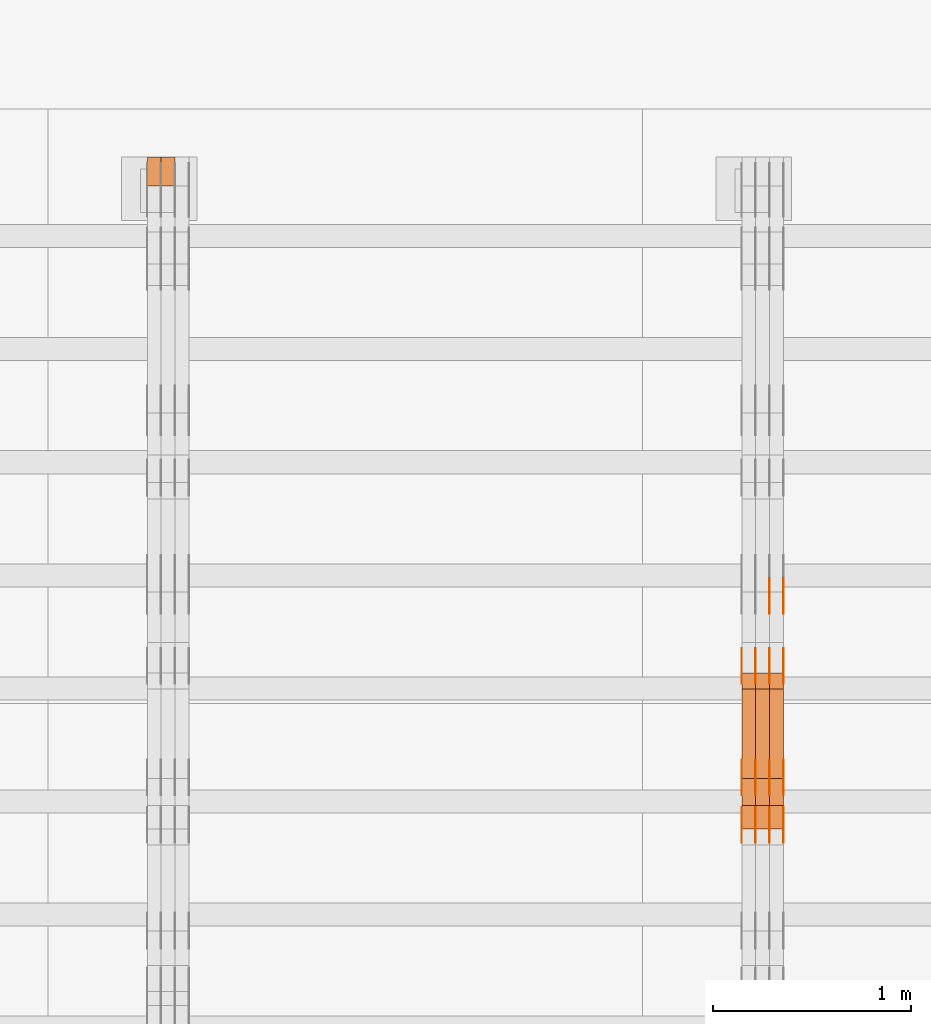
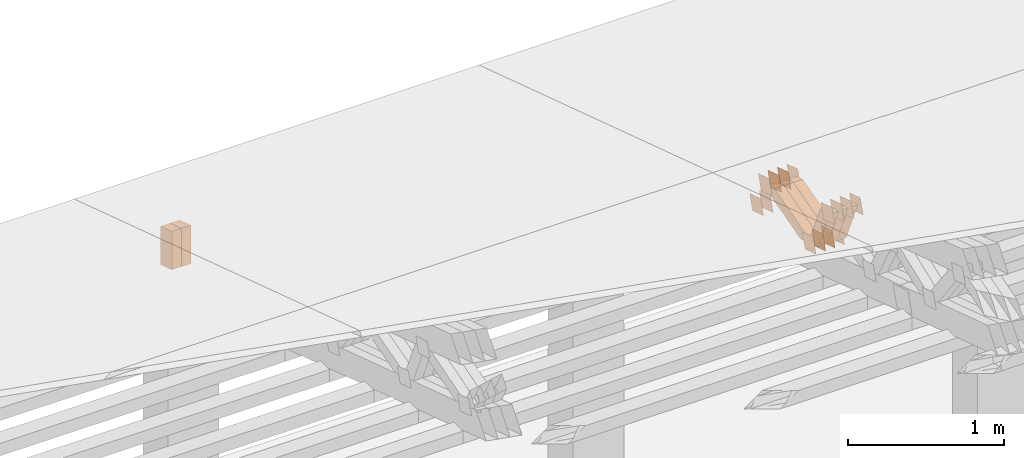
# One storey, part 220 of 385: 28 proxies.
"""IFC2X3 building model written with IfcOpenShell, lengths in millimetres."""

from ifc_helpers import new_model, entity, si_unit, converted_unit, derived_unit, direction, frame, origin, place, context, subcontext, project, spatial, polyline, outline, extrude, source, transform, mapped, material, type_object, type_shapes, element, save


model = new_model("IFC2X3")

# Units and contexts
model_context = context("Model", 3, precision=0.01, world=origin(), true_north=direction((6.12303176911189e-17, 1.0)))
body_context = subcontext(model_context, "Body", "Model", "MODEL_VIEW")
ifc_project = project(units=[si_unit("LENGTHUNIT", "METRE", prefix="MILLI"), si_unit("AREAUNIT", "SQUARE_METRE"), si_unit("VOLUMEUNIT", "CUBIC_METRE"), converted_unit("PLANEANGLEUNIT", "DEGREE", entity("IfcRatioMeasure", 0.0174532925199433), si_unit("PLANEANGLEUNIT", "RADIAN"), dimensions=[0, 0, 0, 0, 0, 0, 0]), si_unit("MASSUNIT", "GRAM", prefix="KILO"), derived_unit("MASSDENSITYUNIT", [(si_unit("MASSUNIT", "GRAM", prefix="KILO"), 1), (si_unit("LENGTHUNIT", "METRE"), -3)]), si_unit("TIMEUNIT", "SECOND"), si_unit("FREQUENCYUNIT", "HERTZ"), si_unit("THERMODYNAMICTEMPERATUREUNIT", "DEGREE_CELSIUS"), derived_unit("THERMALTRANSMITTANCEUNIT", [(si_unit("MASSUNIT", "GRAM", prefix="KILO"), 1), (si_unit("THERMODYNAMICTEMPERATUREUNIT", "KELVIN"), -1), (si_unit("TIMEUNIT", "SECOND"), -3)]), derived_unit("VOLUMETRICFLOWRATEUNIT", [(si_unit("LENGTHUNIT", "METRE"), 3), (si_unit("TIMEUNIT", "SECOND"), -1)]), si_unit("ELECTRICCURRENTUNIT", "AMPERE"), si_unit("ELECTRICVOLTAGEUNIT", "VOLT"), si_unit("POWERUNIT", "WATT"), si_unit("FORCEUNIT", "NEWTON", prefix="KILO"), si_unit("ILLUMINANCEUNIT", "LUX"), si_unit("LUMINOUSFLUXUNIT", "LUMEN"), si_unit("LUMINOUSINTENSITYUNIT", "CANDELA"), derived_unit("USERDEFINED", [(si_unit("MASSUNIT", "GRAM", prefix="KILO"), -1), (si_unit("LENGTHUNIT", "METRE"), -2), (si_unit("TIMEUNIT", "SECOND"), 3), (si_unit("LUMINOUSFLUXUNIT", "LUMEN"), 1)]), derived_unit("LINEARVELOCITYUNIT", [(si_unit("LENGTHUNIT", "METRE"), 1), (si_unit("TIMEUNIT", "SECOND"), -1)]), si_unit("PRESSUREUNIT", "PASCAL"), derived_unit("USERDEFINED", [(si_unit("LENGTHUNIT", "METRE"), -2), (si_unit("MASSUNIT", "GRAM", prefix="KILO"), 1), (si_unit("TIMEUNIT", "SECOND"), -2)])], contexts=[model_context])

# Site, building, storey
site_placement = place(None, origin())
site = spatial("IfcSite", under=ifc_project, at=site_placement, CompositionType="ELEMENT")
building_placement = place(site_placement, origin())
building = spatial("IfcBuilding", under=site, at=building_placement, CompositionType="ELEMENT")
storey_placement = place(building_placement, origin())
storey = spatial("IfcBuildingStorey", under=building, at=storey_placement, Name="Default", CompositionType="ELEMENT", Elevation=0.0)

# Proxies
ifc_material_1 = material(Name="IfcSurfaceStyle #265350")
building_element_proxy_type_1 = type_object("IfcBuildingElementProxyType", PredefinedType="NOTDEFINED", material=ifc_material_1)
shared_shape_1 = source(origin(), body_context, "Body", "SweptSolid", [
    extrude(outline(polyline([(-74.9998888504569, -59.9999264677525), (74.999884859074, -59.9999264677525), (74.9998699895559, 59.9999264677525), (-74.999865998173, 59.9999264677525), (-74.9998888504569, -59.9999264677525)])), frame((74.9999170714918, 60.0000016373507, 0.0), z_axis=(0.0, 0.0, 1.0), x_axis=(-1.0, 0.0, 0.0)), (0.0, 0.0, 1.0), 1.3),
])
type_shapes(building_element_proxy_type_1, [shared_shape_1])
proxy_1_placement = place(building_placement, frame((21386.3, 23182.5962361838, 1409.76695322432), z_axis=(-1.0, 0.0, 0.0), x_axis=(0.0, -0.951056516295154, 0.309016994374948)))
element("IfcBuildingElementProxy", 1, at=proxy_1_placement, inside=storey, type_object=building_element_proxy_type_1, material=ifc_material_1, context=body_context, shape_type="MappedRepresentation", body=[
    mapped(shared_shape_1, transform((0.0, 0.0, 0.0), scale=1.0)),
])
ifc_material_2 = material(Name="IfcSurfaceStyle #265293")
building_element_proxy_type_2 = type_object("IfcBuildingElementProxyType", PredefinedType="NOTDEFINED", material=ifc_material_2)
shared_shape_2 = source(origin(), body_context, "Body", "SweptSolid", [
    extrude(outline(polyline([(-74.9998888504569, -59.9999264677525), (74.999884859074, -59.9999264677525), (74.9998699895559, 59.9999264677525), (-74.999865998173, 59.9999264677525), (-74.9998888504569, -59.9999264677525)])), frame((74.9999170714918, 60.0000016373507, 0.0), z_axis=(0.0, 0.0, 1.0), x_axis=(-1.0, 0.0, 0.0)), (0.0, 0.0, 1.0), 1.3),
])
type_shapes(building_element_proxy_type_2, [shared_shape_2])
proxy_2_placement = place(building_placement, frame((21315.0, 23182.5962361838, 1409.76695322432), z_axis=(-1.0, 0.0, 0.0), x_axis=(0.0, -0.951056516295154, 0.309016994374948)))
element("IfcBuildingElementProxy", 2, at=proxy_2_placement, inside=storey, type_object=building_element_proxy_type_2, material=ifc_material_2, context=body_context, shape_type="MappedRepresentation", body=[
    mapped(shared_shape_2, transform((0.0, 0.0, 0.0), scale=1.0)),
])
ifc_material_3 = material(Name="IfcSurfaceStyle #265236")
building_element_proxy_type_3 = type_object("IfcBuildingElementProxyType", PredefinedType="NOTDEFINED", material=ifc_material_3)
shared_shape_3 = source(origin(), body_context, "Body", "SweptSolid", [
    extrude(outline(polyline([(-74.9998888504569, -59.9999264677525), (74.999884859074, -59.9999264677525), (74.9998699895559, 59.9999264677525), (-74.999865998173, 59.9999264677525), (-74.9998888504569, -59.9999264677525)])), frame((74.9999170714918, 60.0000016373507, 0.0), z_axis=(0.0, 0.0, 1.0), x_axis=(-1.0, 0.0, 0.0)), (0.0, 0.0, 1.0), 1.3),
])
type_shapes(building_element_proxy_type_3, [shared_shape_3])
proxy_3_placement = place(building_placement, frame((21316.3, 23182.5962361838, 1409.76695322432), z_axis=(-1.0, 0.0, 0.0), x_axis=(0.0, -0.951056516295154, 0.309016994374948)))
element("IfcBuildingElementProxy", 3, at=proxy_3_placement, inside=storey, type_object=building_element_proxy_type_3, material=ifc_material_3, context=body_context, shape_type="MappedRepresentation", body=[
    mapped(shared_shape_3, transform((0.0, 0.0, 0.0), scale=1.0)),
])
ifc_material_4 = material(Name="IfcSurfaceStyle #265179")
building_element_proxy_type_4 = type_object("IfcBuildingElementProxyType", PredefinedType="NOTDEFINED", material=ifc_material_4)
shared_shape_4 = source(origin(), body_context, "Body", "SweptSolid", [
    extrude(outline(polyline([(-74.9998888504569, -59.9999264677525), (74.999884859074, -59.9999264677525), (74.9998699895559, 59.9999264677525), (-74.999865998173, 59.9999264677525), (-74.9998888504569, -59.9999264677525)])), frame((74.9999170714918, 60.0000016373507, 0.0), z_axis=(0.0, 0.0, 1.0), x_axis=(-1.0, 0.0, 0.0)), (0.0, 0.0, 1.0), 1.29999999999999),
])
type_shapes(building_element_proxy_type_4, [shared_shape_4])
proxy_4_placement = place(building_placement, frame((21245.0, 23182.5962361838, 1409.76695322432), z_axis=(-1.0, 0.0, 0.0), x_axis=(0.0, -0.951056516295154, 0.309016994374948)))
element("IfcBuildingElementProxy", 4, at=proxy_4_placement, inside=storey, type_object=building_element_proxy_type_4, material=ifc_material_4, context=body_context, shape_type="MappedRepresentation", body=[
    mapped(shared_shape_4, transform((0.0, 0.0, 0.0), scale=1.0)),
])
ifc_material_5 = material(Name="IfcSurfaceStyle #265122")
building_element_proxy_type_5 = type_object("IfcBuildingElementProxyType", PredefinedType="NOTDEFINED", material=ifc_material_5)
shared_shape_5 = source(origin(), body_context, "Body", "SweptSolid", [
    extrude(outline(polyline([(-74.9998888504569, -59.9999264677525), (74.999884859074, -59.9999264677525), (74.9998699895559, 59.9999264677525), (-74.999865998173, 59.9999264677525), (-74.9998888504569, -59.9999264677525)])), frame((74.9999170714918, 60.0000016373507, 0.0), z_axis=(0.0, 0.0, 1.0), x_axis=(-1.0, 0.0, 0.0)), (0.0, 0.0, 1.0), 1.29999999999999),
])
type_shapes(building_element_proxy_type_5, [shared_shape_5])
proxy_5_placement = place(building_placement, frame((21246.3, 23182.5962361838, 1409.76695322432), z_axis=(-1.0, 0.0, 0.0), x_axis=(0.0, -0.951056516295154, 0.309016994374948)))
element("IfcBuildingElementProxy", 5, at=proxy_5_placement, inside=storey, type_object=building_element_proxy_type_5, material=ifc_material_5, context=body_context, shape_type="MappedRepresentation", body=[
    mapped(shared_shape_5, transform((0.0, 0.0, 0.0), scale=1.0)),
])
ifc_material_6 = material(Name="IfcSurfaceStyle #265065")
building_element_proxy_type_6 = type_object("IfcBuildingElementProxyType", PredefinedType="NOTDEFINED", material=ifc_material_6)
shared_shape_6 = source(origin(), body_context, "Body", "SweptSolid", [
    extrude(outline(polyline([(-74.9998888504569, -59.9999264677525), (74.999884859074, -59.9999264677525), (74.9998699895559, 59.9999264677525), (-74.999865998173, 59.9999264677525), (-74.9998888504569, -59.9999264677525)])), frame((74.9999170714918, 60.0000016373507, 0.0), z_axis=(0.0, 0.0, 1.0), x_axis=(-1.0, 0.0, 0.0)), (0.0, 0.0, 1.0), 1.29999999999999),
])
type_shapes(building_element_proxy_type_6, [shared_shape_6])
proxy_6_placement = place(building_placement, frame((21175.0, 23182.5962361838, 1409.76695322432), z_axis=(-1.0, 0.0, 0.0), x_axis=(0.0, -0.951056516295154, 0.309016994374948)))
element("IfcBuildingElementProxy", 6, at=proxy_6_placement, inside=storey, type_object=building_element_proxy_type_6, material=ifc_material_6, context=body_context, shape_type="MappedRepresentation", body=[
    mapped(shared_shape_6, transform((0.0, 0.0, 0.0), scale=1.0)),
])
ifc_material_7 = material(Name="IfcSurfaceStyle #265008")
building_element_proxy_type_7 = type_object("IfcBuildingElementProxyType", PredefinedType="NOTDEFINED", material=ifc_material_7)
shared_shape_7 = source(origin(), body_context, "Body", "SweptSolid", [
    extrude(outline(polyline([(-75.000111611545, -60.0000599592451), (75.0000887592491, -60.0000599592451), (75.000111611545, 60.0000599592451), (-75.0000887592492, 60.0000599592451), (-75.000111611545, -60.0000599592451)])), frame((75.000111611545, 60.0000599592451, 0.0), z_axis=(0.0, 0.0, 1.0), x_axis=(-1.0, 0.0, 0.0)), (0.0, 0.0, 1.0), 1.3),
])
type_shapes(building_element_proxy_type_7, [shared_shape_7])
proxy_7_placement = place(building_placement, frame((21386.3, 23422.738257852, 1031.33757447264), z_axis=(-1.0, 0.0, 0.0), x_axis=(0.0, -0.951056516295124, 0.309016994375039)))
element("IfcBuildingElementProxy", 7, at=proxy_7_placement, inside=storey, type_object=building_element_proxy_type_7, material=ifc_material_7, context=body_context, shape_type="MappedRepresentation", body=[
    mapped(shared_shape_7, transform((0.0, 0.0, 0.0), scale=1.0)),
])
ifc_material_8 = material(Name="IfcSurfaceStyle #264951")
building_element_proxy_type_8 = type_object("IfcBuildingElementProxyType", PredefinedType="NOTDEFINED", material=ifc_material_8)
shared_shape_8 = source(origin(), body_context, "Body", "SweptSolid", [
    extrude(outline(polyline([(-75.000111611545, -60.0000599592451), (75.0000887592491, -60.0000599592451), (75.000111611545, 60.0000599592451), (-75.0000887592492, 60.0000599592451), (-75.000111611545, -60.0000599592451)])), frame((75.000111611545, 60.0000599592451, 0.0), z_axis=(0.0, 0.0, 1.0), x_axis=(-1.0, 0.0, 0.0)), (0.0, 0.0, 1.0), 1.3),
])
type_shapes(building_element_proxy_type_8, [shared_shape_8])
proxy_8_placement = place(building_placement, frame((21315.0, 23422.738257852, 1031.33757447264), z_axis=(-1.0, 0.0, 0.0), x_axis=(0.0, -0.951056516295124, 0.309016994375039)))
element("IfcBuildingElementProxy", 8, at=proxy_8_placement, inside=storey, type_object=building_element_proxy_type_8, material=ifc_material_8, context=body_context, shape_type="MappedRepresentation", body=[
    mapped(shared_shape_8, transform((0.0, 0.0, 0.0), scale=1.0)),
])
ifc_material_9 = material(Name="IfcSurfaceStyle #264894")
building_element_proxy_type_9 = type_object("IfcBuildingElementProxyType", PredefinedType="NOTDEFINED", material=ifc_material_9)
shared_shape_9 = source(origin(), body_context, "Body", "SweptSolid", [
    extrude(outline(polyline([(-75.000111611545, -60.0000599592451), (75.0000887592491, -60.0000599592451), (75.000111611545, 60.0000599592451), (-75.0000887592492, 60.0000599592451), (-75.000111611545, -60.0000599592451)])), frame((75.000111611545, 60.0000599592451, 0.0), z_axis=(0.0, 0.0, 1.0), x_axis=(-1.0, 0.0, 0.0)), (0.0, 0.0, 1.0), 1.3),
])
type_shapes(building_element_proxy_type_9, [shared_shape_9])
proxy_9_placement = place(building_placement, frame((21316.3, 23422.738257852, 1031.33757447264), z_axis=(-1.0, 0.0, 0.0), x_axis=(0.0, -0.951056516295124, 0.309016994375039)))
element("IfcBuildingElementProxy", 9, at=proxy_9_placement, inside=storey, type_object=building_element_proxy_type_9, material=ifc_material_9, context=body_context, shape_type="MappedRepresentation", body=[
    mapped(shared_shape_9, transform((0.0, 0.0, 0.0), scale=1.0)),
])
ifc_material_10 = material(Name="IfcSurfaceStyle #264837")
building_element_proxy_type_10 = type_object("IfcBuildingElementProxyType", PredefinedType="NOTDEFINED", material=ifc_material_10)
shared_shape_10 = source(origin(), body_context, "Body", "SweptSolid", [
    extrude(outline(polyline([(-75.000111611545, -60.0000599592451), (75.0000887592491, -60.0000599592451), (75.000111611545, 60.0000599592451), (-75.0000887592492, 60.0000599592451), (-75.000111611545, -60.0000599592451)])), frame((75.000111611545, 60.0000599592451, 0.0), z_axis=(0.0, 0.0, 1.0), x_axis=(-1.0, 0.0, 0.0)), (0.0, 0.0, 1.0), 1.29999999999999),
])
type_shapes(building_element_proxy_type_10, [shared_shape_10])
proxy_10_placement = place(building_placement, frame((21245.0, 23422.738257852, 1031.33757447264), z_axis=(-1.0, 0.0, 0.0), x_axis=(0.0, -0.951056516295124, 0.309016994375039)))
element("IfcBuildingElementProxy", 10, at=proxy_10_placement, inside=storey, type_object=building_element_proxy_type_10, material=ifc_material_10, context=body_context, shape_type="MappedRepresentation", body=[
    mapped(shared_shape_10, transform((0.0, 0.0, 0.0), scale=1.0)),
])
ifc_material_11 = material(Name="IfcSurfaceStyle #264780")
building_element_proxy_type_11 = type_object("IfcBuildingElementProxyType", PredefinedType="NOTDEFINED", material=ifc_material_11)
shared_shape_11 = source(origin(), body_context, "Body", "SweptSolid", [
    extrude(outline(polyline([(-75.000111611545, -60.0000599592451), (75.0000887592491, -60.0000599592451), (75.000111611545, 60.0000599592451), (-75.0000887592492, 60.0000599592451), (-75.000111611545, -60.0000599592451)])), frame((75.000111611545, 60.0000599592451, 0.0), z_axis=(0.0, 0.0, 1.0), x_axis=(-1.0, 0.0, 0.0)), (0.0, 0.0, 1.0), 1.29999999999999),
])
type_shapes(building_element_proxy_type_11, [shared_shape_11])
proxy_11_placement = place(building_placement, frame((21246.3, 23422.738257852, 1031.33757447264), z_axis=(-1.0, 0.0, 0.0), x_axis=(0.0, -0.951056516295124, 0.309016994375039)))
element("IfcBuildingElementProxy", 11, at=proxy_11_placement, inside=storey, type_object=building_element_proxy_type_11, material=ifc_material_11, context=body_context, shape_type="MappedRepresentation", body=[
    mapped(shared_shape_11, transform((0.0, 0.0, 0.0), scale=1.0)),
])
ifc_material_12 = material(Name="IfcSurfaceStyle #264723")
building_element_proxy_type_12 = type_object("IfcBuildingElementProxyType", PredefinedType="NOTDEFINED", material=ifc_material_12)
shared_shape_12 = source(origin(), body_context, "Body", "SweptSolid", [
    extrude(outline(polyline([(-75.000111611545, -60.0000599592451), (75.0000887592491, -60.0000599592451), (75.000111611545, 60.0000599592451), (-75.0000887592492, 60.0000599592451), (-75.000111611545, -60.0000599592451)])), frame((75.000111611545, 60.0000599592451, 0.0), z_axis=(0.0, 0.0, 1.0), x_axis=(-1.0, 0.0, 0.0)), (0.0, 0.0, 1.0), 1.29999999999999),
])
type_shapes(building_element_proxy_type_12, [shared_shape_12])
proxy_12_placement = place(building_placement, frame((21175.0, 23422.738257852, 1031.33757447264), z_axis=(-1.0, 0.0, 0.0), x_axis=(0.0, -0.951056516295124, 0.309016994375039)))
element("IfcBuildingElementProxy", 12, at=proxy_12_placement, inside=storey, type_object=building_element_proxy_type_12, material=ifc_material_12, context=body_context, shape_type="MappedRepresentation", body=[
    mapped(shared_shape_12, transform((0.0, 0.0, 0.0), scale=1.0)),
])
ifc_material_13 = material(Name="IfcSurfaceStyle #264324")
building_element_proxy_type_13 = type_object("IfcBuildingElementProxyType", PredefinedType="NOTDEFINED", material=ifc_material_13)
shared_shape_13 = source(origin(), body_context, "Body", "SweptSolid", [
    extrude(outline(polyline([(-74.9999766548731, -60.0000019113547), (75.000223715922, -60.0000019113547), (74.9997444633404, 60.0000019113548), (-74.9999915243893, 60.0000019113547), (-74.9999766548731, -60.0000019113547)])), frame((75.0002237159219, 60.0000770809529, 0.0), z_axis=(0.0, 0.0, 1.0), x_axis=(-1.0, 0.0, 0.0)), (0.0, 0.0, 1.0), 1.3),
])
type_shapes(building_element_proxy_type_13, [shared_shape_13])
proxy_13_placement = place(building_placement, frame((21386.3, 23985.88473314, 1148.76266928562), z_axis=(-1.0, 0.0, 0.0), x_axis=(0.0, -0.951056516295154, 0.309016994374948)))
element("IfcBuildingElementProxy", 13, at=proxy_13_placement, inside=storey, type_object=building_element_proxy_type_13, material=ifc_material_13, context=body_context, shape_type="MappedRepresentation", body=[
    mapped(shared_shape_13, transform((0.0, 0.0, 0.0), scale=1.0)),
])
ifc_material_14 = material(Name="IfcSurfaceStyle #264267")
building_element_proxy_type_14 = type_object("IfcBuildingElementProxyType", PredefinedType="NOTDEFINED", material=ifc_material_14)
shared_shape_14 = source(origin(), body_context, "Body", "SweptSolid", [
    extrude(outline(polyline([(-74.9999766548731, -60.0000019113547), (75.000223715922, -60.0000019113547), (74.9997444633404, 60.0000019113548), (-74.9999915243893, 60.0000019113547), (-74.9999766548731, -60.0000019113547)])), frame((75.0002237159219, 60.0000770809529, 0.0), z_axis=(0.0, 0.0, 1.0), x_axis=(-1.0, 0.0, 0.0)), (0.0, 0.0, 1.0), 1.3),
])
type_shapes(building_element_proxy_type_14, [shared_shape_14])
proxy_14_placement = place(building_placement, frame((21315.0, 23985.88473314, 1148.76266928562), z_axis=(-1.0, 0.0, 0.0), x_axis=(0.0, -0.951056516295154, 0.309016994374948)))
element("IfcBuildingElementProxy", 14, at=proxy_14_placement, inside=storey, type_object=building_element_proxy_type_14, material=ifc_material_14, context=body_context, shape_type="MappedRepresentation", body=[
    mapped(shared_shape_14, transform((0.0, 0.0, 0.0), scale=1.0)),
])
ifc_material_15 = material(Name="IfcSurfaceStyle #264210")
building_element_proxy_type_15 = type_object("IfcBuildingElementProxyType", PredefinedType="NOTDEFINED", material=ifc_material_15)
shared_shape_15 = source(origin(), body_context, "Body", "SweptSolid", [
    extrude(outline(polyline([(-74.9999766548731, -60.0000019113547), (75.000223715922, -60.0000019113547), (74.9997444633404, 60.0000019113548), (-74.9999915243893, 60.0000019113547), (-74.9999766548731, -60.0000019113547)])), frame((75.0002237159219, 60.0000770809529, 0.0), z_axis=(0.0, 0.0, 1.0), x_axis=(-1.0, 0.0, 0.0)), (0.0, 0.0, 1.0), 1.3),
])
type_shapes(building_element_proxy_type_15, [shared_shape_15])
proxy_15_placement = place(building_placement, frame((21316.3, 23985.88473314, 1148.76266928562), z_axis=(-1.0, 0.0, 0.0), x_axis=(0.0, -0.951056516295154, 0.309016994374948)))
element("IfcBuildingElementProxy", 15, at=proxy_15_placement, inside=storey, type_object=building_element_proxy_type_15, material=ifc_material_15, context=body_context, shape_type="MappedRepresentation", body=[
    mapped(shared_shape_15, transform((0.0, 0.0, 0.0), scale=1.0)),
])
ifc_material_16 = material(Name="IfcSurfaceStyle #264153")
building_element_proxy_type_16 = type_object("IfcBuildingElementProxyType", PredefinedType="NOTDEFINED", material=ifc_material_16)
shared_shape_16 = source(origin(), body_context, "Body", "SweptSolid", [
    extrude(outline(polyline([(-74.9999766548731, -60.0000019113547), (75.000223715922, -60.0000019113547), (74.9997444633404, 60.0000019113548), (-74.9999915243893, 60.0000019113547), (-74.9999766548731, -60.0000019113547)])), frame((75.0002237159219, 60.0000770809529, 0.0), z_axis=(0.0, 0.0, 1.0), x_axis=(-1.0, 0.0, 0.0)), (0.0, 0.0, 1.0), 1.29999999999999),
])
type_shapes(building_element_proxy_type_16, [shared_shape_16])
proxy_16_placement = place(building_placement, frame((21245.0, 23985.88473314, 1148.76266928562), z_axis=(-1.0, 0.0, 0.0), x_axis=(0.0, -0.951056516295154, 0.309016994374948)))
element("IfcBuildingElementProxy", 16, at=proxy_16_placement, inside=storey, type_object=building_element_proxy_type_16, material=ifc_material_16, context=body_context, shape_type="MappedRepresentation", body=[
    mapped(shared_shape_16, transform((0.0, 0.0, 0.0), scale=1.0)),
])
ifc_material_17 = material(Name="IfcSurfaceStyle #264096")
building_element_proxy_type_17 = type_object("IfcBuildingElementProxyType", PredefinedType="NOTDEFINED", material=ifc_material_17)
shared_shape_17 = source(origin(), body_context, "Body", "SweptSolid", [
    extrude(outline(polyline([(-74.9999766548731, -60.0000019113547), (75.000223715922, -60.0000019113547), (74.9997444633404, 60.0000019113548), (-74.9999915243893, 60.0000019113547), (-74.9999766548731, -60.0000019113547)])), frame((75.0002237159219, 60.0000770809529, 0.0), z_axis=(0.0, 0.0, 1.0), x_axis=(-1.0, 0.0, 0.0)), (0.0, 0.0, 1.0), 1.29999999999999),
])
type_shapes(building_element_proxy_type_17, [shared_shape_17])
proxy_17_placement = place(building_placement, frame((21246.3, 23985.88473314, 1148.76266928562), z_axis=(-1.0, 0.0, 0.0), x_axis=(0.0, -0.951056516295154, 0.309016994374948)))
element("IfcBuildingElementProxy", 17, at=proxy_17_placement, inside=storey, type_object=building_element_proxy_type_17, material=ifc_material_17, context=body_context, shape_type="MappedRepresentation", body=[
    mapped(shared_shape_17, transform((0.0, 0.0, 0.0), scale=1.0)),
])
ifc_material_18 = material(Name="IfcSurfaceStyle #264039")
building_element_proxy_type_18 = type_object("IfcBuildingElementProxyType", PredefinedType="NOTDEFINED", material=ifc_material_18)
shared_shape_18 = source(origin(), body_context, "Body", "SweptSolid", [
    extrude(outline(polyline([(-74.9999766548731, -60.0000019113547), (75.000223715922, -60.0000019113547), (74.9997444633404, 60.0000019113548), (-74.9999915243893, 60.0000019113547), (-74.9999766548731, -60.0000019113547)])), frame((75.0002237159219, 60.0000770809529, 0.0), z_axis=(0.0, 0.0, 1.0), x_axis=(-1.0, 0.0, 0.0)), (0.0, 0.0, 1.0), 1.29999999999999),
])
type_shapes(building_element_proxy_type_18, [shared_shape_18])
proxy_18_placement = place(building_placement, frame((21175.0, 23985.88473314, 1148.76266928562), z_axis=(-1.0, 0.0, 0.0), x_axis=(0.0, -0.951056516295154, 0.309016994374948)))
element("IfcBuildingElementProxy", 18, at=proxy_18_placement, inside=storey, type_object=building_element_proxy_type_18, material=ifc_material_18, context=body_context, shape_type="MappedRepresentation", body=[
    mapped(shared_shape_18, transform((0.0, 0.0, 0.0), scale=1.0)),
])
ifc_material_19 = material(Name="IfcSurfaceStyle #263982")
building_element_proxy_type_19 = type_object("IfcBuildingElementProxyType", PredefinedType="NOTDEFINED", material=ifc_material_19)
shared_shape_19 = source(origin(), body_context, "Body", "SweptSolid", [
    extrude(outline(polyline([(-74.9998841352385, -59.9999554917014), (74.9998707133932, -59.9999554917014), (74.999874704788, 59.9999554917014), (-74.9998612829427, 59.9999554917014), (-74.9998841352385, -59.9999554917014)])), frame((75.0000802775471, 60.0000306612849, 0.0), z_axis=(0.0, 0.0, 1.0), x_axis=(-1.0, 0.0, 0.0)), (0.0, 0.0, 1.0), 1.3),
])
type_shapes(building_element_proxy_type_19, [shared_shape_19])
proxy_19_placement = place(building_placement, frame((21386.3, 24338.8869142613, 728.405515087805), z_axis=(-1.0, 0.0, 0.0), x_axis=(0.0, -0.951056516295124, 0.309016994375039)))
element("IfcBuildingElementProxy", 19, at=proxy_19_placement, inside=storey, type_object=building_element_proxy_type_19, material=ifc_material_19, context=body_context, shape_type="MappedRepresentation", body=[
    mapped(shared_shape_19, transform((0.0, 0.0, 0.0), scale=1.0)),
])
ifc_material_20 = material(Name="IfcSurfaceStyle #263925")
building_element_proxy_type_20 = type_object("IfcBuildingElementProxyType", PredefinedType="NOTDEFINED", material=ifc_material_20)
shared_shape_20 = source(origin(), body_context, "Body", "SweptSolid", [
    extrude(outline(polyline([(-74.9998841352385, -59.9999554917014), (74.9998707133932, -59.9999554917014), (74.999874704788, 59.9999554917014), (-74.9998612829427, 59.9999554917014), (-74.9998841352385, -59.9999554917014)])), frame((75.0000802775471, 60.0000306612849, 0.0), z_axis=(0.0, 0.0, 1.0), x_axis=(-1.0, 0.0, 0.0)), (0.0, 0.0, 1.0), 1.3),
])
type_shapes(building_element_proxy_type_20, [shared_shape_20])
proxy_20_placement = place(building_placement, frame((21315.0, 24338.8869142613, 728.405515087805), z_axis=(-1.0, 0.0, 0.0), x_axis=(0.0, -0.951056516295124, 0.309016994375039)))
element("IfcBuildingElementProxy", 20, at=proxy_20_placement, inside=storey, type_object=building_element_proxy_type_20, material=ifc_material_20, context=body_context, shape_type="MappedRepresentation", body=[
    mapped(shared_shape_20, transform((0.0, 0.0, 0.0), scale=1.0)),
])
ifc_material_21 = material(Name="IfcSurfaceStyle #252498")
building_element_proxy_type_21 = type_object("IfcBuildingElementProxyType", Name="T1-W48 252496", PredefinedType="NOTDEFINED", material=ifc_material_21)
shared_shape_21 = source(origin(), body_context, "Body", "SweptSolid", [
    extrude(outline(polyline([(-179.014659681673, -47.5001725722734), (164.970934255612, -47.5001725722734), (158.689466064455, -0.000154807462590734), (117.249257288395, 47.5002499760047), (-261.894997926789, 47.5002499760047), (-179.014659681673, -47.5001725722734)])), frame((164.970934255612, 47.5002499760047, 0.0), z_axis=(0.0, 0.0, 1.0), x_axis=(-1.0, 0.0, 0.0)), (0.0, 0.0, 1.0), 70.0),
])
type_shapes(building_element_proxy_type_21, [shared_shape_21])
proxy_21_placement = place(building_placement, frame((21385.0, 23276.999081075, 1103.96808602322), z_axis=(-1.0, 0.0, 0.0), x_axis=(0.0, -0.392372359952232, 0.919806463961586)))
element("IfcBuildingElementProxy", 21, at=proxy_21_placement, inside=storey, type_object=building_element_proxy_type_21, material=ifc_material_21, Name="T1-W48", context=body_context, shape_type="MappedRepresentation", body=[
    mapped(shared_shape_21, transform((0.0, 0.0, 0.0), scale=1.0)),
])
ifc_material_22 = material(Name="IfcSurfaceStyle #252432")
building_element_proxy_type_22 = type_object("IfcBuildingElementProxyType", Name="T1-W48 252430", PredefinedType="NOTDEFINED", material=ifc_material_22)
shared_shape_22 = source(origin(), body_context, "Body", "SweptSolid", [
    extrude(outline(polyline([(-179.014659681673, -47.5001725722734), (164.970934255612, -47.5001725722734), (158.689466064455, -0.000154807462590734), (117.249257288395, 47.5002499760047), (-261.894997926789, 47.5002499760047), (-179.014659681673, -47.5001725722734)])), frame((164.970934255612, 47.5002499760047, 0.0), z_axis=(0.0, 0.0, 1.0), x_axis=(-1.0, 0.0, 0.0)), (0.0, 0.0, 1.0), 70.0),
])
type_shapes(building_element_proxy_type_22, [shared_shape_22])
proxy_22_placement = place(building_placement, frame((21315.0, 23276.999081075, 1103.96808602322), z_axis=(-1.0, 0.0, 0.0), x_axis=(0.0, -0.392372359952232, 0.919806463961586)))
element("IfcBuildingElementProxy", 22, at=proxy_22_placement, inside=storey, type_object=building_element_proxy_type_22, material=ifc_material_22, Name="T1-W48", context=body_context, shape_type="MappedRepresentation", body=[
    mapped(shared_shape_22, transform((0.0, 0.0, 0.0), scale=1.0)),
])
ifc_material_23 = material(Name="IfcSurfaceStyle #252366")
building_element_proxy_type_23 = type_object("IfcBuildingElementProxyType", Name="T1-W48 252364", PredefinedType="NOTDEFINED", material=ifc_material_23)
shared_shape_23 = source(origin(), body_context, "Body", "SweptSolid", [
    extrude(outline(polyline([(-179.014659681673, -47.5001725722734), (164.970934255612, -47.5001725722734), (158.689466064455, -0.000154807462590734), (117.249257288395, 47.5002499760047), (-261.894997926789, 47.5002499760047), (-179.014659681673, -47.5001725722734)])), frame((164.970934255612, 47.5002499760047, 0.0), z_axis=(0.0, 0.0, 1.0), x_axis=(-1.0, 0.0, 0.0)), (0.0, 0.0, 1.0), 70.0),
])
type_shapes(building_element_proxy_type_23, [shared_shape_23])
proxy_23_placement = place(building_placement, frame((21245.0, 23276.999081075, 1103.96808602322), z_axis=(-1.0, 0.0, 0.0), x_axis=(0.0, -0.392372359952232, 0.919806463961586)))
element("IfcBuildingElementProxy", 23, at=proxy_23_placement, inside=storey, type_object=building_element_proxy_type_23, material=ifc_material_23, Name="T1-W48", context=body_context, shape_type="MappedRepresentation", body=[
    mapped(shared_shape_23, transform((0.0, 0.0, 0.0), scale=1.0)),
])
ifc_material_24 = material(Name="IfcSurfaceStyle #252102")
building_element_proxy_type_24 = type_object("IfcBuildingElementProxyType", Name="T1-W16 252100", PredefinedType="NOTDEFINED", material=ifc_material_24)
shared_shape_24 = source(origin(), body_context, "Body", "SweptSolid", [
    extrude(outline(polyline([(-370.757125176074, -47.4999438400901), (145.934648032773, -47.4999438400902), (217.511780472151, -4.11857860007858e-05), (234.91308660316, 47.4999644329832), (-227.602389932009, 47.4999644329832), (-370.757125176074, -47.4999438400901)])), frame((234.913162148205, 47.5000075544853, 0.0), z_axis=(0.0, 0.0, 1.0), x_axis=(-1.0, 0.0, 0.0)), (0.0, 0.0, 1.0), 70.0),
])
type_shapes(building_element_proxy_type_24, [shared_shape_24])
proxy_24_placement = place(building_placement, frame((21385.0, 23927.1704945031, 1199.43003244777), z_axis=(-1.0, 0.0, 0.0), x_axis=(0.0, -0.963308155550006, -0.268397834288666)))
element("IfcBuildingElementProxy", 24, at=proxy_24_placement, inside=storey, type_object=building_element_proxy_type_24, material=ifc_material_24, Name="T1-W16", context=body_context, shape_type="MappedRepresentation", body=[
    mapped(shared_shape_24, transform((0.0, 0.0, 0.0), scale=1.0)),
])
ifc_material_25 = material(Name="IfcSurfaceStyle #252036")
building_element_proxy_type_25 = type_object("IfcBuildingElementProxyType", Name="T1-W16 252034", PredefinedType="NOTDEFINED", material=ifc_material_25)
shared_shape_25 = source(origin(), body_context, "Body", "SweptSolid", [
    extrude(outline(polyline([(-370.757125176074, -47.4999438400901), (145.934648032773, -47.4999438400902), (217.511780472151, -4.11857860007858e-05), (234.91308660316, 47.4999644329832), (-227.602389932009, 47.4999644329832), (-370.757125176074, -47.4999438400901)])), frame((234.913162148205, 47.5000075544853, 0.0), z_axis=(0.0, 0.0, 1.0), x_axis=(-1.0, 0.0, 0.0)), (0.0, 0.0, 1.0), 70.0),
])
type_shapes(building_element_proxy_type_25, [shared_shape_25])
proxy_25_placement = place(building_placement, frame((21315.0, 23927.1704945031, 1199.43003244777), z_axis=(-1.0, 0.0, 0.0), x_axis=(0.0, -0.963308155550006, -0.268397834288666)))
element("IfcBuildingElementProxy", 25, at=proxy_25_placement, inside=storey, type_object=building_element_proxy_type_25, material=ifc_material_25, Name="T1-W16", context=body_context, shape_type="MappedRepresentation", body=[
    mapped(shared_shape_25, transform((0.0, 0.0, 0.0), scale=1.0)),
])
ifc_material_26 = material(Name="IfcSurfaceStyle #251970")
building_element_proxy_type_26 = type_object("IfcBuildingElementProxyType", Name="T1-W16 251968", PredefinedType="NOTDEFINED", material=ifc_material_26)
shared_shape_26 = source(origin(), body_context, "Body", "SweptSolid", [
    extrude(outline(polyline([(-370.757125176074, -47.4999438400901), (145.934648032773, -47.4999438400902), (217.511780472151, -4.11857860007858e-05), (234.91308660316, 47.4999644329832), (-227.602389932009, 47.4999644329832), (-370.757125176074, -47.4999438400901)])), frame((234.913162148205, 47.5000075544853, 0.0), z_axis=(0.0, 0.0, 1.0), x_axis=(-1.0, 0.0, 0.0)), (0.0, 0.0, 1.0), 70.0),
])
type_shapes(building_element_proxy_type_26, [shared_shape_26])
proxy_26_placement = place(building_placement, frame((21245.0, 23927.1704945031, 1199.43003244777), z_axis=(-1.0, 0.0, 0.0), x_axis=(0.0, -0.963308155550006, -0.268397834288666)))
element("IfcBuildingElementProxy", 26, at=proxy_26_placement, inside=storey, type_object=building_element_proxy_type_26, material=ifc_material_26, Name="T1-W16", context=body_context, shape_type="MappedRepresentation", body=[
    mapped(shared_shape_26, transform((0.0, 0.0, 0.0), scale=1.0)),
])
ifc_material_27 = material(Name="IfcSurfaceStyle #215066")
building_element_proxy_type_27 = type_object("IfcBuildingElementProxyType", Name="T1-E2 215064", PredefinedType="NOTDEFINED", material=ifc_material_27)
shared_shape_27 = source(origin(), body_context, "Body", "SweptSolid", [
    extrude(outline(polyline([(-126.644535064697, -72.4999999999998), (173.757884979248, -72.4999999999998), (126.644542694092, 72.4999999999998), (-173.757892608642, 72.4999999999998), (-126.644535064697, -72.4999999999998)])), frame((173.757890653796, 72.5000000000002, 0.0), z_axis=(0.0, 0.0, 1.0), x_axis=(-1.0, 0.0, 0.0)), (0.0, 0.0, 1.0), 70.0),
])
type_shapes(building_element_proxy_type_27, [shared_shape_27])
proxy_27_placement = place(building_placement, frame((18315.0, 26500.0, 442.078222227283), z_axis=(-1.0, 0.0, 0.0), x_axis=(0.0, 0.0, -1.0)))
element("IfcBuildingElementProxy", 27, at=proxy_27_placement, inside=storey, type_object=building_element_proxy_type_27, material=ifc_material_27, Name="T1-E2", context=body_context, shape_type="MappedRepresentation", body=[
    mapped(shared_shape_27, transform((0.0, 0.0, 0.0), scale=1.0)),
])
ifc_material_28 = material(Name="IfcSurfaceStyle #215009")
building_element_proxy_type_28 = type_object("IfcBuildingElementProxyType", Name="T1-E2 215007", PredefinedType="NOTDEFINED", material=ifc_material_28)
shared_shape_28 = source(origin(), body_context, "Body", "SweptSolid", [
    extrude(outline(polyline([(-126.644535064697, -72.4999999999998), (173.757884979248, -72.4999999999998), (126.644542694092, 72.4999999999998), (-173.757892608642, 72.4999999999998), (-126.644535064697, -72.4999999999998)])), frame((173.757890653796, 72.5000000000002, 0.0), z_axis=(0.0, 0.0, 1.0), x_axis=(-1.0, 0.0, 0.0)), (0.0, 0.0, 1.0), 70.0),
])
type_shapes(building_element_proxy_type_28, [shared_shape_28])
proxy_28_placement = place(building_placement, frame((18245.0, 26500.0, 442.078222227283), z_axis=(-1.0, 0.0, 0.0), x_axis=(0.0, 0.0, -1.0)))
element("IfcBuildingElementProxy", 28, at=proxy_28_placement, inside=storey, type_object=building_element_proxy_type_28, material=ifc_material_28, Name="T1-E2", context=body_context, shape_type="MappedRepresentation", body=[
    mapped(shared_shape_28, transform((0.0, 0.0, 0.0), scale=1.0)),
])

save(model, "model.ifc")
